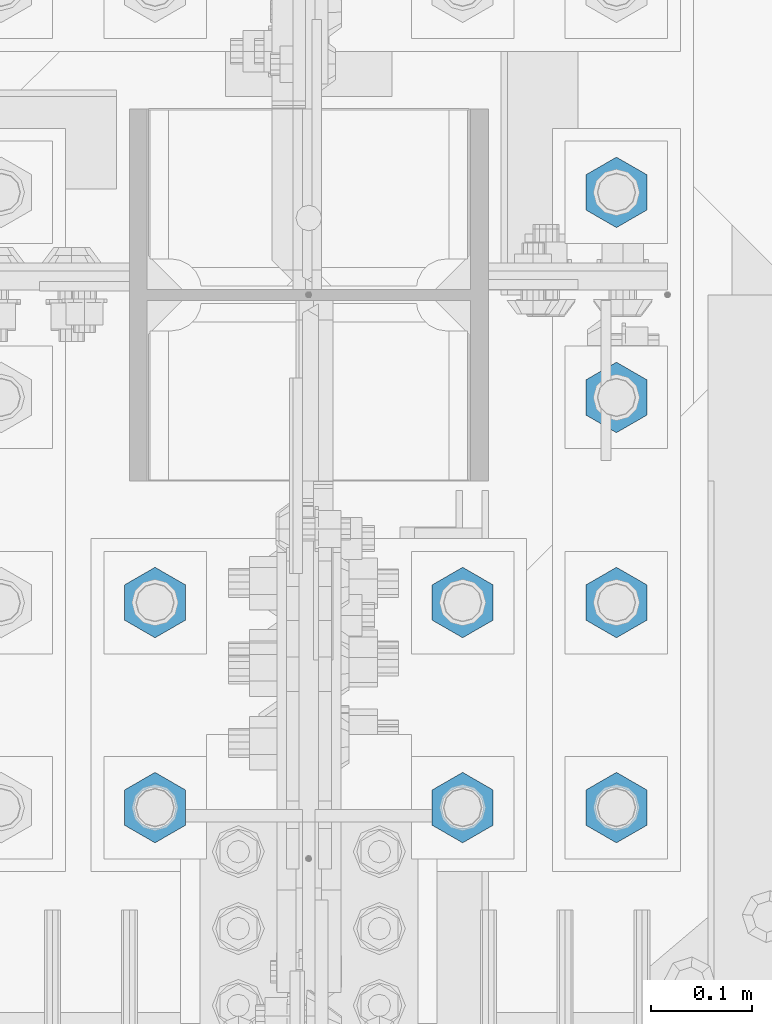
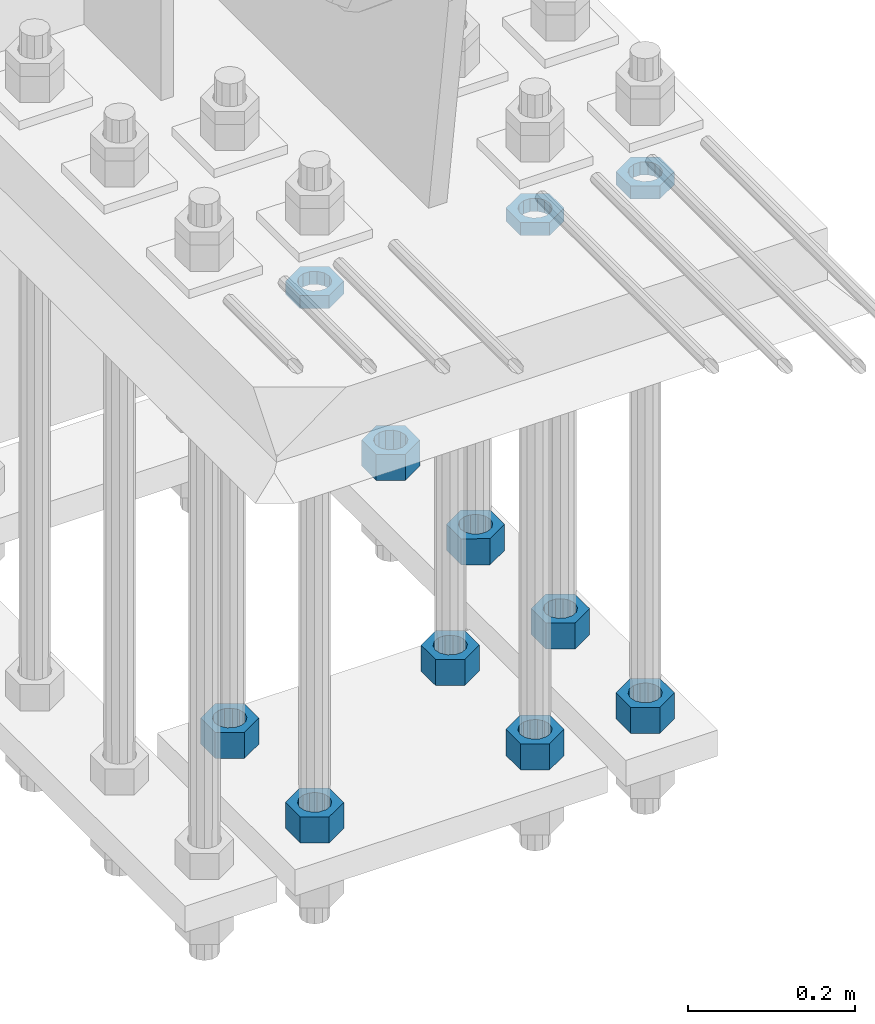
# One storey, part 2838 of 3843: 11 beams, 1 element without a shape of its own.
"""IFC2X3 building model written with IfcOpenShell, lengths in millimetres."""

from ifc_helpers import new_model, si_unit, frame, origin_with_axes, place, context, subcontext, project, spatial, faceted_brep, material, type_object, element, aggregate, save


model = new_model("IFC2X3")

# Units and contexts
model_context = context("Model", 3, precision=1e-05, world=origin_with_axes())
body_context = subcontext(model_context, "Body", "Model", "MODEL_VIEW")
ifc_project = project(units=[si_unit("LENGTHUNIT", "METRE", prefix="MILLI"), si_unit("AREAUNIT", "SQUARE_METRE"), si_unit("VOLUMEUNIT", "CUBIC_METRE"), si_unit("MASSUNIT", "GRAM", prefix="KILO"), si_unit("TIMEUNIT", "SECOND"), si_unit("PLANEANGLEUNIT", "RADIAN"), si_unit("SOLIDANGLEUNIT", "STERADIAN"), si_unit("THERMODYNAMICTEMPERATUREUNIT", "DEGREE_CELSIUS"), si_unit("LUMINOUSINTENSITYUNIT", "LUMEN")], contexts=[model_context])

# Site, building, storey
site_placement = place(None, origin_with_axes())
site = spatial("IfcSite", under=ifc_project, at=site_placement, CompositionType="ELEMENT")
building_placement = place(site_placement, origin_with_axes())
building = spatial("IfcBuilding", under=site, at=building_placement, Name="Undefined", CompositionType="ELEMENT")
storey_placement = place(building_placement, origin_with_axes())
storey = spatial("IfcBuildingStorey", under=building, at=storey_placement, Name="Undefined", CompositionType="ELEMENT", Elevation=0.0)

# Assembly, beams
assembly_placement = place(storey_placement, origin_with_axes())
assembly = element("IfcElementAssembly", 1, at=assembly_placement, inside=storey, Name="TEMPLATE", AssemblyPlace="NOTDEFINED", PredefinedType="RIGID_FRAME")
ifc_material = material(Name="STEEL/A572-50")
beam_type_1 = type_object("IfcBeamType", Name="1-1/2_HEAVY_HEX_NUT", PredefinedType="NOTDEFINED")
beam_1_placement = place(assembly_placement, frame((76860.4, 25107.9, 29298.9000015259), z_axis=(-1.0, 0.0, 0.0), x_axis=(0.0, 0.0, -1.0)))
beam_1 = element("IfcBeam", 2, at=beam_1_placement, type_object=beam_type_1, material=ifc_material, Name="NUT", ObjectType="1-1/2_HEAVY_HEX_NUT", context=body_context, shape_type="Brep", body=[
    faceted_brep([(0.0, -34.9199981689453, 0.0), (0.0, -17.4599990844727, -30.25), (38.0999999999985, -17.4599990844727, -30.25), (38.0999999999985, -34.9199981689453, 0.0), (0.0, 17.4599990844727, -30.25), (38.0999999999985, 17.4599990844727, -30.25), (0.0, 34.9199981689453, 0.0), (38.0999999999985, 34.9199981689453, 0.0), (0.0, 17.4599990844727, 30.25), (38.0999999999985, 17.4599990844727, 30.25), (0.0, -17.4599990844727, 30.25), (38.0999999999985, -17.4599990844727, 30.25), (0.0, 0.0, 20.6399993896484), (0.0, 8.9553601105581, 18.5959968835959), (38.0999999999985, 8.9553601105581, 18.5959968835959), (38.0999999999985, 0.0, 20.6399993896484), (0.0, 16.1370013209525, 12.8688291298167), (38.0999999999985, 16.1370013209525, 12.8688291298167), (0.0, 20.1225115123816, 4.59283194104501), (38.0999999999985, 20.1225115123816, 4.59283194104501), (0.0, 20.1225115123816, -4.59283194104501), (38.0999999999985, 20.1225115123816, -4.59283194104501), (0.0, 16.1370013209525, -12.8688291298167), (38.0999999999985, 16.1370013209525, -12.8688291298167), (0.0, 8.9553601105581, -18.5959968835959), (38.0999999999985, 8.9553601105581, -18.5959968835959), (0.0, 0.0, -20.6399993896484), (38.0999999999985, 0.0, -20.6399993896484), (0.0, -8.9553601105581, -18.5959968835959), (38.0999999999985, -8.9553601105581, -18.5959968835959), (0.0, -16.1370013209525, -12.8688291298167), (38.0999999999985, -16.1370013209525, -12.8688291298167), (0.0, -20.1225115123816, -4.59283194104501), (38.0999999999985, -20.1225115123816, -4.59283194104501), (0.0, -20.1225115123816, 4.59283194104501), (38.0999999999985, -20.1225115123816, 4.59283194104501), (0.0, -16.1370013209525, 12.8688291298167), (38.0999999999985, -16.1370013209525, 12.8688291298167), (0.0, -8.9553601105581, 18.5959968835959), (38.0999999999985, -8.9553601105581, 18.5959968835959)], [[[0, 1, 2, 3]], [[1, 4, 5, 2]], [[4, 6, 7, 5]], [[6, 8, 9, 7]], [[8, 10, 11, 9]], [[10, 0, 3, 11]], [[12, 13, 14, 15]], [[13, 16, 17, 14]], [[16, 18, 19, 17]], [[18, 20, 21, 19]], [[20, 22, 23, 21]], [[22, 24, 25, 23]], [[24, 26, 27, 25]], [[26, 28, 29, 27]], [[28, 30, 31, 29]], [[30, 32, 33, 31]], [[32, 34, 35, 33]], [[34, 36, 37, 35]], [[36, 38, 39, 37]], [[38, 12, 15, 39]], [[5, 7, 9, 11, 3, 2], [17, 19, 21, 23, 25, 27, 29, 31, 33, 35, 37, 39, 15, 14]], [[10, 8, 6, 4, 1, 0], [38, 36, 34, 32, 30, 28, 26, 24, 22, 20, 18, 16, 13, 12]]]),
])
beam_2_placement = place(assembly_placement, frame((76860.4, 25311.1, 29298.9000015259), z_axis=(-1.0, 0.0, 0.0), x_axis=(0.0, 0.0, -1.0)))
beam_2 = element("IfcBeam", 3, at=beam_2_placement, type_object=beam_type_1, material=ifc_material, Name="NUT", ObjectType="1-1/2_HEAVY_HEX_NUT", context=body_context, shape_type="Brep", body=[
    faceted_brep([(0.0, -34.9199981689453, 0.0), (0.0, -17.4599990844727, -30.25), (38.0999999999985, -17.4599990844727, -30.25), (38.0999999999985, -34.9199981689453, 0.0), (0.0, 17.4599990844727, -30.25), (38.0999999999985, 17.4599990844727, -30.25), (0.0, 34.9199981689453, 0.0), (38.0999999999985, 34.9199981689453, 0.0), (0.0, 17.4599990844727, 30.25), (38.0999999999985, 17.4599990844727, 30.25), (0.0, -17.4599990844727, 30.25), (38.0999999999985, -17.4599990844727, 30.25), (0.0, 0.0, 20.6399993896484), (0.0, 8.9553601105581, 18.5959968835959), (38.0999999999985, 8.9553601105581, 18.5959968835959), (38.0999999999985, 0.0, 20.6399993896484), (0.0, 16.1370013209525, 12.8688291298167), (38.0999999999985, 16.1370013209525, 12.8688291298167), (0.0, 20.1225115123816, 4.59283194104501), (38.0999999999985, 20.1225115123816, 4.59283194104501), (0.0, 20.1225115123816, -4.59283194104501), (38.0999999999985, 20.1225115123816, -4.59283194104501), (0.0, 16.1370013209525, -12.8688291298167), (38.0999999999985, 16.1370013209525, -12.8688291298167), (0.0, 8.9553601105581, -18.5959968835959), (38.0999999999985, 8.9553601105581, -18.5959968835959), (0.0, 0.0, -20.6399993896484), (38.0999999999985, 0.0, -20.6399993896484), (0.0, -8.9553601105581, -18.5959968835959), (38.0999999999985, -8.9553601105581, -18.5959968835959), (0.0, -16.1370013209525, -12.8688291298167), (38.0999999999985, -16.1370013209525, -12.8688291298167), (0.0, -20.1225115123816, -4.59283194104501), (38.0999999999985, -20.1225115123816, -4.59283194104501), (0.0, -20.1225115123816, 4.59283194104501), (38.0999999999985, -20.1225115123816, 4.59283194104501), (0.0, -16.1370013209525, 12.8688291298167), (38.0999999999985, -16.1370013209525, 12.8688291298167), (0.0, -8.9553601105581, 18.5959968835959), (38.0999999999985, -8.9553601105581, 18.5959968835959)], [[[0, 1, 2, 3]], [[1, 4, 5, 2]], [[4, 6, 7, 5]], [[6, 8, 9, 7]], [[8, 10, 11, 9]], [[10, 0, 3, 11]], [[12, 13, 14, 15]], [[13, 16, 17, 14]], [[16, 18, 19, 17]], [[18, 20, 21, 19]], [[20, 22, 23, 21]], [[22, 24, 25, 23]], [[24, 26, 27, 25]], [[26, 28, 29, 27]], [[28, 30, 31, 29]], [[30, 32, 33, 31]], [[32, 34, 35, 33]], [[34, 36, 37, 35]], [[36, 38, 39, 37]], [[38, 12, 15, 39]], [[5, 7, 9, 11, 3, 2], [17, 19, 21, 23, 25, 27, 29, 31, 33, 35, 37, 39, 15, 14]], [[10, 8, 6, 4, 1, 0], [38, 36, 34, 32, 30, 28, 26, 24, 22, 20, 18, 16, 13, 12]]]),
])
beam_3_placement = place(assembly_placement, frame((77165.2, 25107.9, 29298.9000015259), z_axis=(-1.0, 0.0, 0.0), x_axis=(0.0, 0.0, -1.0)))
beam_3 = element("IfcBeam", 4, at=beam_3_placement, type_object=beam_type_1, material=ifc_material, Name="NUT", ObjectType="1-1/2_HEAVY_HEX_NUT", context=body_context, shape_type="Brep", body=[
    faceted_brep([(0.0, -34.9199981689453, 0.0), (0.0, -17.4599990844727, -30.25), (38.0999999999985, -17.4599990844727, -30.25), (38.0999999999985, -34.9199981689453, 0.0), (0.0, 17.4599990844727, -30.25), (38.0999999999985, 17.4599990844727, -30.25), (0.0, 34.9199981689453, 0.0), (38.0999999999985, 34.9199981689453, 0.0), (0.0, 17.4599990844727, 30.25), (38.0999999999985, 17.4599990844727, 30.25), (0.0, -17.4599990844727, 30.25), (38.0999999999985, -17.4599990844727, 30.25), (0.0, 0.0, 20.6399993896484), (0.0, 8.9553601105581, 18.5959968835959), (38.0999999999985, 8.9553601105581, 18.5959968835959), (38.0999999999985, 0.0, 20.6399993896484), (0.0, 16.1370013209525, 12.8688291298167), (38.0999999999985, 16.1370013209525, 12.8688291298167), (0.0, 20.1225115123816, 4.59283194104501), (38.0999999999985, 20.1225115123816, 4.59283194104501), (0.0, 20.1225115123816, -4.59283194104501), (38.0999999999985, 20.1225115123816, -4.59283194104501), (0.0, 16.1370013209525, -12.8688291298167), (38.0999999999985, 16.1370013209525, -12.8688291298167), (0.0, 8.9553601105581, -18.5959968835959), (38.0999999999985, 8.9553601105581, -18.5959968835959), (0.0, 0.0, -20.6399993896484), (38.0999999999985, 0.0, -20.6399993896484), (0.0, -8.9553601105581, -18.5959968835959), (38.0999999999985, -8.9553601105581, -18.5959968835959), (0.0, -16.1370013209525, -12.8688291298167), (38.0999999999985, -16.1370013209525, -12.8688291298167), (0.0, -20.1225115123816, -4.59283194104501), (38.0999999999985, -20.1225115123816, -4.59283194104501), (0.0, -20.1225115123816, 4.59283194104501), (38.0999999999985, -20.1225115123816, 4.59283194104501), (0.0, -16.1370013209525, 12.8688291298167), (38.0999999999985, -16.1370013209525, 12.8688291298167), (0.0, -8.9553601105581, 18.5959968835959), (38.0999999999985, -8.9553601105581, 18.5959968835959)], [[[0, 1, 2, 3]], [[1, 4, 5, 2]], [[4, 6, 7, 5]], [[6, 8, 9, 7]], [[8, 10, 11, 9]], [[10, 0, 3, 11]], [[12, 13, 14, 15]], [[13, 16, 17, 14]], [[16, 18, 19, 17]], [[18, 20, 21, 19]], [[20, 22, 23, 21]], [[22, 24, 25, 23]], [[24, 26, 27, 25]], [[26, 28, 29, 27]], [[28, 30, 31, 29]], [[30, 32, 33, 31]], [[32, 34, 35, 33]], [[34, 36, 37, 35]], [[36, 38, 39, 37]], [[38, 12, 15, 39]], [[5, 7, 9, 11, 3, 2], [17, 19, 21, 23, 25, 27, 29, 31, 33, 35, 37, 39, 15, 14]], [[10, 8, 6, 4, 1, 0], [38, 36, 34, 32, 30, 28, 26, 24, 22, 20, 18, 16, 13, 12]]]),
])
beam_4_placement = place(assembly_placement, frame((77165.2, 25311.1, 29298.9000015259), z_axis=(-1.0, 0.0, 0.0), x_axis=(0.0, 0.0, -1.0)))
beam_4 = element("IfcBeam", 5, at=beam_4_placement, type_object=beam_type_1, material=ifc_material, Name="NUT", ObjectType="1-1/2_HEAVY_HEX_NUT", context=body_context, shape_type="Brep", body=[
    faceted_brep([(0.0, -34.9199981689453, 0.0), (0.0, -17.4599990844727, -30.25), (38.0999999999985, -17.4599990844727, -30.25), (38.0999999999985, -34.9199981689453, 0.0), (0.0, 17.4599990844727, -30.25), (38.0999999999985, 17.4599990844727, -30.25), (0.0, 34.9199981689453, 0.0), (38.0999999999985, 34.9199981689453, 0.0), (0.0, 17.4599990844727, 30.25), (38.0999999999985, 17.4599990844727, 30.25), (0.0, -17.4599990844727, 30.25), (38.0999999999985, -17.4599990844727, 30.25), (0.0, 0.0, 20.6399993896484), (0.0, 8.9553601105581, 18.5959968835959), (38.0999999999985, 8.9553601105581, 18.5959968835959), (38.0999999999985, 0.0, 20.6399993896484), (0.0, 16.1370013209525, 12.8688291298167), (38.0999999999985, 16.1370013209525, 12.8688291298167), (0.0, 20.1225115123816, 4.59283194104501), (38.0999999999985, 20.1225115123816, 4.59283194104501), (0.0, 20.1225115123816, -4.59283194104501), (38.0999999999985, 20.1225115123816, -4.59283194104501), (0.0, 16.1370013209525, -12.8688291298167), (38.0999999999985, 16.1370013209525, -12.8688291298167), (0.0, 8.9553601105581, -18.5959968835959), (38.0999999999985, 8.9553601105581, -18.5959968835959), (0.0, 0.0, -20.6399993896484), (38.0999999999985, 0.0, -20.6399993896484), (0.0, -8.9553601105581, -18.5959968835959), (38.0999999999985, -8.9553601105581, -18.5959968835959), (0.0, -16.1370013209525, -12.8688291298167), (38.0999999999985, -16.1370013209525, -12.8688291298167), (0.0, -20.1225115123816, -4.59283194104501), (38.0999999999985, -20.1225115123816, -4.59283194104501), (0.0, -20.1225115123816, 4.59283194104501), (38.0999999999985, -20.1225115123816, 4.59283194104501), (0.0, -16.1370013209525, 12.8688291298167), (38.0999999999985, -16.1370013209525, 12.8688291298167), (0.0, -8.9553601105581, 18.5959968835959), (38.0999999999985, -8.9553601105581, 18.5959968835959)], [[[0, 1, 2, 3]], [[1, 4, 5, 2]], [[4, 6, 7, 5]], [[6, 8, 9, 7]], [[8, 10, 11, 9]], [[10, 0, 3, 11]], [[12, 13, 14, 15]], [[13, 16, 17, 14]], [[16, 18, 19, 17]], [[18, 20, 21, 19]], [[20, 22, 23, 21]], [[22, 24, 25, 23]], [[24, 26, 27, 25]], [[26, 28, 29, 27]], [[28, 30, 31, 29]], [[30, 32, 33, 31]], [[32, 34, 35, 33]], [[34, 36, 37, 35]], [[36, 38, 39, 37]], [[38, 12, 15, 39]], [[5, 7, 9, 11, 3, 2], [17, 19, 21, 23, 25, 27, 29, 31, 33, 35, 37, 39, 15, 14]], [[10, 8, 6, 4, 1, 0], [38, 36, 34, 32, 30, 28, 26, 24, 22, 20, 18, 16, 13, 12]]]),
])
beam_5_placement = place(assembly_placement, frame((77317.6, 25717.5, 29298.9000015259), z_axis=(1.0, 0.0, 0.0), x_axis=(0.0, 0.0, -1.0)))
beam_5 = element("IfcBeam", 6, at=beam_5_placement, type_object=beam_type_1, material=ifc_material, Name="NUT", ObjectType="1-1/2_HEAVY_HEX_NUT", context=body_context, shape_type="Brep", body=[
    faceted_brep([(0.0, -34.9199981689453, 0.0), (0.0, -17.4599990844727, -30.25), (38.0999999999985, -17.4599990844727, -30.25), (38.0999999999985, -34.9199981689453, 0.0), (0.0, 17.4599990844727, -30.25), (38.0999999999985, 17.4599990844727, -30.25), (0.0, 34.9199981689453, 0.0), (38.0999999999985, 34.9199981689453, 0.0), (0.0, 17.4599990844727, 30.25), (38.0999999999985, 17.4599990844727, 30.25), (0.0, -17.4599990844727, 30.25), (38.0999999999985, -17.4599990844727, 30.25), (0.0, 0.0, 20.6399993896484), (0.0, 8.9553601105581, 18.5959968835959), (38.0999999999985, 8.9553601105581, 18.5959968835959), (38.0999999999985, 0.0, 20.6399993896484), (0.0, 16.1370013209525, 12.8688291298167), (38.0999999999985, 16.1370013209525, 12.8688291298167), (0.0, 20.1225115123816, 4.59283194104501), (38.0999999999985, 20.1225115123816, 4.59283194104501), (0.0, 20.1225115123816, -4.59283194104501), (38.0999999999985, 20.1225115123816, -4.59283194104501), (0.0, 16.1370013209525, -12.8688291298167), (38.0999999999985, 16.1370013209525, -12.8688291298167), (0.0, 8.9553601105581, -18.5959968835959), (38.0999999999985, 8.9553601105581, -18.5959968835959), (0.0, 0.0, -20.6399993896484), (38.0999999999985, 0.0, -20.6399993896484), (0.0, -8.9553601105581, -18.5959968835959), (38.0999999999985, -8.9553601105581, -18.5959968835959), (0.0, -16.1370013209525, -12.8688291298167), (38.0999999999985, -16.1370013209525, -12.8688291298167), (0.0, -20.1225115123816, -4.59283194104501), (38.0999999999985, -20.1225115123816, -4.59283194104501), (0.0, -20.1225115123816, 4.59283194104501), (38.0999999999985, -20.1225115123816, 4.59283194104501), (0.0, -16.1370013209525, 12.8688291298167), (38.0999999999985, -16.1370013209525, 12.8688291298167), (0.0, -8.9553601105581, 18.5959968835959), (38.0999999999985, -8.9553601105581, 18.5959968835959)], [[[0, 1, 2, 3]], [[1, 4, 5, 2]], [[4, 6, 7, 5]], [[6, 8, 9, 7]], [[8, 10, 11, 9]], [[10, 0, 3, 11]], [[12, 13, 14, 15]], [[13, 16, 17, 14]], [[16, 18, 19, 17]], [[18, 20, 21, 19]], [[20, 22, 23, 21]], [[22, 24, 25, 23]], [[24, 26, 27, 25]], [[26, 28, 29, 27]], [[28, 30, 31, 29]], [[30, 32, 33, 31]], [[32, 34, 35, 33]], [[34, 36, 37, 35]], [[36, 38, 39, 37]], [[38, 12, 15, 39]], [[5, 7, 9, 11, 3, 2], [17, 19, 21, 23, 25, 27, 29, 31, 33, 35, 37, 39, 15, 14]], [[10, 8, 6, 4, 1, 0], [38, 36, 34, 32, 30, 28, 26, 24, 22, 20, 18, 16, 13, 12]]]),
])
beam_6_placement = place(assembly_placement, frame((77317.6, 25514.3, 29298.9000015259), z_axis=(1.0, 0.0, 0.0), x_axis=(0.0, 0.0, -1.0)))
beam_6 = element("IfcBeam", 7, at=beam_6_placement, type_object=beam_type_1, material=ifc_material, Name="NUT", ObjectType="1-1/2_HEAVY_HEX_NUT", context=body_context, shape_type="Brep", body=[
    faceted_brep([(0.0, -34.9199981689453, 0.0), (0.0, -17.4599990844727, -30.25), (38.0999999999985, -17.4599990844727, -30.25), (38.0999999999985, -34.9199981689453, 0.0), (0.0, 17.4599990844727, -30.25), (38.0999999999985, 17.4599990844727, -30.25), (0.0, 34.9199981689453, 0.0), (38.0999999999985, 34.9199981689453, 0.0), (0.0, 17.4599990844727, 30.25), (38.0999999999985, 17.4599990844727, 30.25), (0.0, -17.4599990844727, 30.25), (38.0999999999985, -17.4599990844727, 30.25), (0.0, 0.0, 20.6399993896484), (0.0, 8.9553601105581, 18.5959968835959), (38.0999999999985, 8.9553601105581, 18.5959968835959), (38.0999999999985, 0.0, 20.6399993896484), (0.0, 16.1370013209525, 12.8688291298167), (38.0999999999985, 16.1370013209525, 12.8688291298167), (0.0, 20.1225115123816, 4.59283194104501), (38.0999999999985, 20.1225115123816, 4.59283194104501), (0.0, 20.1225115123816, -4.59283194104501), (38.0999999999985, 20.1225115123816, -4.59283194104501), (0.0, 16.1370013209525, -12.8688291298167), (38.0999999999985, 16.1370013209525, -12.8688291298167), (0.0, 8.9553601105581, -18.5959968835959), (38.0999999999985, 8.9553601105581, -18.5959968835959), (0.0, 0.0, -20.6399993896484), (38.0999999999985, 0.0, -20.6399993896484), (0.0, -8.9553601105581, -18.5959968835959), (38.0999999999985, -8.9553601105581, -18.5959968835959), (0.0, -16.1370013209525, -12.8688291298167), (38.0999999999985, -16.1370013209525, -12.8688291298167), (0.0, -20.1225115123816, -4.59283194104501), (38.0999999999985, -20.1225115123816, -4.59283194104501), (0.0, -20.1225115123816, 4.59283194104501), (38.0999999999985, -20.1225115123816, 4.59283194104501), (0.0, -16.1370013209525, 12.8688291298167), (38.0999999999985, -16.1370013209525, 12.8688291298167), (0.0, -8.9553601105581, 18.5959968835959), (38.0999999999985, -8.9553601105581, 18.5959968835959)], [[[0, 1, 2, 3]], [[1, 4, 5, 2]], [[4, 6, 7, 5]], [[6, 8, 9, 7]], [[8, 10, 11, 9]], [[10, 0, 3, 11]], [[12, 13, 14, 15]], [[13, 16, 17, 14]], [[16, 18, 19, 17]], [[18, 20, 21, 19]], [[20, 22, 23, 21]], [[22, 24, 25, 23]], [[24, 26, 27, 25]], [[26, 28, 29, 27]], [[28, 30, 31, 29]], [[30, 32, 33, 31]], [[32, 34, 35, 33]], [[34, 36, 37, 35]], [[36, 38, 39, 37]], [[38, 12, 15, 39]], [[5, 7, 9, 11, 3, 2], [17, 19, 21, 23, 25, 27, 29, 31, 33, 35, 37, 39, 15, 14]], [[10, 8, 6, 4, 1, 0], [38, 36, 34, 32, 30, 28, 26, 24, 22, 20, 18, 16, 13, 12]]]),
])
beam_7_placement = place(assembly_placement, frame((77317.6, 25311.1, 29298.9000015259), z_axis=(-1.0, 0.0, 0.0), x_axis=(0.0, 0.0, -1.0)))
beam_7 = element("IfcBeam", 8, at=beam_7_placement, type_object=beam_type_1, material=ifc_material, Name="NUT", ObjectType="1-1/2_HEAVY_HEX_NUT", context=body_context, shape_type="Brep", body=[
    faceted_brep([(0.0, -34.9199981689453, 0.0), (0.0, -17.4599990844727, -30.25), (38.0999999999985, -17.4599990844727, -30.25), (38.0999999999985, -34.9199981689453, 0.0), (0.0, 17.4599990844727, -30.25), (38.0999999999985, 17.4599990844727, -30.25), (0.0, 34.9199981689453, 0.0), (38.0999999999985, 34.9199981689453, 0.0), (0.0, 17.4599990844727, 30.25), (38.0999999999985, 17.4599990844727, 30.25), (0.0, -17.4599990844727, 30.25), (38.0999999999985, -17.4599990844727, 30.25), (0.0, 0.0, 20.6399993896484), (0.0, 8.9553601105581, 18.5959968835959), (38.0999999999985, 8.9553601105581, 18.5959968835959), (38.0999999999985, 0.0, 20.6399993896484), (0.0, 16.1370013209525, 12.8688291298167), (38.0999999999985, 16.1370013209525, 12.8688291298167), (0.0, 20.1225115123816, 4.59283194104501), (38.0999999999985, 20.1225115123816, 4.59283194104501), (0.0, 20.1225115123816, -4.59283194104501), (38.0999999999985, 20.1225115123816, -4.59283194104501), (0.0, 16.1370013209525, -12.8688291298167), (38.0999999999985, 16.1370013209525, -12.8688291298167), (0.0, 8.9553601105581, -18.5959968835959), (38.0999999999985, 8.9553601105581, -18.5959968835959), (0.0, 0.0, -20.6399993896484), (38.0999999999985, 0.0, -20.6399993896484), (0.0, -8.9553601105581, -18.5959968835959), (38.0999999999985, -8.9553601105581, -18.5959968835959), (0.0, -16.1370013209525, -12.8688291298167), (38.0999999999985, -16.1370013209525, -12.8688291298167), (0.0, -20.1225115123816, -4.59283194104501), (38.0999999999985, -20.1225115123816, -4.59283194104501), (0.0, -20.1225115123816, 4.59283194104501), (38.0999999999985, -20.1225115123816, 4.59283194104501), (0.0, -16.1370013209525, 12.8688291298167), (38.0999999999985, -16.1370013209525, 12.8688291298167), (0.0, -8.9553601105581, 18.5959968835959), (38.0999999999985, -8.9553601105581, 18.5959968835959)], [[[0, 1, 2, 3]], [[1, 4, 5, 2]], [[4, 6, 7, 5]], [[6, 8, 9, 7]], [[8, 10, 11, 9]], [[10, 0, 3, 11]], [[12, 13, 14, 15]], [[13, 16, 17, 14]], [[16, 18, 19, 17]], [[18, 20, 21, 19]], [[20, 22, 23, 21]], [[22, 24, 25, 23]], [[24, 26, 27, 25]], [[26, 28, 29, 27]], [[28, 30, 31, 29]], [[30, 32, 33, 31]], [[32, 34, 35, 33]], [[34, 36, 37, 35]], [[36, 38, 39, 37]], [[38, 12, 15, 39]], [[5, 7, 9, 11, 3, 2], [17, 19, 21, 23, 25, 27, 29, 31, 33, 35, 37, 39, 15, 14]], [[10, 8, 6, 4, 1, 0], [38, 36, 34, 32, 30, 28, 26, 24, 22, 20, 18, 16, 13, 12]]]),
])
beam_8_placement = place(assembly_placement, frame((77317.6, 25107.9, 29298.9000015259), z_axis=(-1.0, 0.0, 0.0), x_axis=(0.0, 0.0, -1.0)))
beam_8 = element("IfcBeam", 9, at=beam_8_placement, type_object=beam_type_1, material=ifc_material, Name="NUT", ObjectType="1-1/2_HEAVY_HEX_NUT", context=body_context, shape_type="Brep", body=[
    faceted_brep([(0.0, -34.9199981689453, 0.0), (0.0, -17.4599990844727, -30.25), (38.0999999999985, -17.4599990844727, -30.25), (38.0999999999985, -34.9199981689453, 0.0), (0.0, 17.4599990844727, -30.25), (38.0999999999985, 17.4599990844727, -30.25), (0.0, 34.9199981689453, 0.0), (38.0999999999985, 34.9199981689453, 0.0), (0.0, 17.4599990844727, 30.25), (38.0999999999985, 17.4599990844727, 30.25), (0.0, -17.4599990844727, 30.25), (38.0999999999985, -17.4599990844727, 30.25), (0.0, 0.0, 20.6399993896484), (0.0, 8.9553601105581, 18.5959968835959), (38.0999999999985, 8.9553601105581, 18.5959968835959), (38.0999999999985, 0.0, 20.6399993896484), (0.0, 16.1370013209525, 12.8688291298167), (38.0999999999985, 16.1370013209525, 12.8688291298167), (0.0, 20.1225115123816, 4.59283194104501), (38.0999999999985, 20.1225115123816, 4.59283194104501), (0.0, 20.1225115123816, -4.59283194104501), (38.0999999999985, 20.1225115123816, -4.59283194104501), (0.0, 16.1370013209525, -12.8688291298167), (38.0999999999985, 16.1370013209525, -12.8688291298167), (0.0, 8.9553601105581, -18.5959968835959), (38.0999999999985, 8.9553601105581, -18.5959968835959), (0.0, 0.0, -20.6399993896484), (38.0999999999985, 0.0, -20.6399993896484), (0.0, -8.9553601105581, -18.5959968835959), (38.0999999999985, -8.9553601105581, -18.5959968835959), (0.0, -16.1370013209525, -12.8688291298167), (38.0999999999985, -16.1370013209525, -12.8688291298167), (0.0, -20.1225115123816, -4.59283194104501), (38.0999999999985, -20.1225115123816, -4.59283194104501), (0.0, -20.1225115123816, 4.59283194104501), (38.0999999999985, -20.1225115123816, 4.59283194104501), (0.0, -16.1370013209525, 12.8688291298167), (38.0999999999985, -16.1370013209525, 12.8688291298167), (0.0, -8.9553601105581, 18.5959968835959), (38.0999999999985, -8.9553601105581, 18.5959968835959)], [[[0, 1, 2, 3]], [[1, 4, 5, 2]], [[4, 6, 7, 5]], [[6, 8, 9, 7]], [[8, 10, 11, 9]], [[10, 0, 3, 11]], [[12, 13, 14, 15]], [[13, 16, 17, 14]], [[16, 18, 19, 17]], [[18, 20, 21, 19]], [[20, 22, 23, 21]], [[22, 24, 25, 23]], [[24, 26, 27, 25]], [[26, 28, 29, 27]], [[28, 30, 31, 29]], [[30, 32, 33, 31]], [[32, 34, 35, 33]], [[34, 36, 37, 35]], [[36, 38, 39, 37]], [[38, 12, 15, 39]], [[5, 7, 9, 11, 3, 2], [17, 19, 21, 23, 25, 27, 29, 31, 33, 35, 37, 39, 15, 14]], [[10, 8, 6, 4, 1, 0], [38, 36, 34, 32, 30, 28, 26, 24, 22, 20, 18, 16, 13, 12]]]),
])
beam_type_2 = type_object("IfcBeamType", Name="1-1/2_HALF_NUT", PredefinedType="NOTDEFINED")
beam_9_placement = place(assembly_placement, frame((77165.2, 25107.9, 30060.9), z_axis=(-1.0, 0.0, 0.0), x_axis=(0.0, 0.0, -1.0)))
beam_9 = element("IfcBeam", 10, at=beam_9_placement, type_object=beam_type_2, material=ifc_material, Name="NUT", ObjectType="1-1/2_HALF_NUT", context=body_context, shape_type="Brep", body=[
    faceted_brep([(0.0, -34.9199981689453, 0.0), (0.0, -17.4599990844727, -30.25), (19.0500000000029, -17.4599990844727, -30.25), (19.0500000000029, -34.9199981689453, 0.0), (0.0, 17.4599990844727, -30.25), (19.0500000000029, 17.4599990844727, -30.25), (0.0, 34.9199981689453, 0.0), (19.0500000000029, 34.9199981689453, 0.0), (0.0, 17.4599990844727, 30.25), (19.0500000000029, 17.4599990844727, 30.25), (0.0, -17.4599990844727, 30.25), (19.0500000000029, -17.4599990844727, 30.25), (0.0, 0.0, 20.6399993896484), (0.0, 8.9553601105581, 18.5959968835959), (19.0500000000029, 8.95536011056538, 18.5959968835959), (19.0500000000029, 0.0, 20.6399993896484), (0.0, 16.1370013209525, 12.8688291298167), (19.0500000000029, 16.1370013209489, 12.8688291298167), (0.0, 20.1225115123816, 4.59283194104501), (19.0500000000029, 20.1225115123852, 4.59283194104501), (0.0, 20.1225115123816, -4.59283194104501), (19.0500000000029, 20.1225115123852, -4.59283194104501), (0.0, 16.1370013209525, -12.8688291298167), (19.0500000000029, 16.1370013209489, -12.8688291298167), (0.0, 8.9553601105581, -18.5959968835959), (19.0500000000029, 8.95536011056538, -18.5959968835959), (0.0, 0.0, -20.6399993896484), (19.0500000000029, 0.0, -20.6399993896484), (0.0, -8.9553601105581, -18.5959968835959), (19.0500000000029, -8.95536011056538, -18.5959968835959), (0.0, -16.1370013209525, -12.8688291298167), (19.0500000000029, -16.1370013209489, -12.8688291298167), (0.0, -20.1225115123816, -4.59283194104501), (19.0500000000029, -20.1225115123852, -4.59283194104501), (0.0, -20.1225115123816, 4.59283194104501), (19.0500000000029, -20.1225115123852, 4.59283194104501), (0.0, -16.1370013209525, 12.8688291298167), (19.0500000000029, -16.1370013209489, 12.8688291298167), (0.0, -8.9553601105581, 18.5959968835959), (19.0500000000029, -8.95536011056538, 18.5959968835959)], [[[0, 1, 2, 3]], [[1, 4, 5, 2]], [[4, 6, 7, 5]], [[6, 8, 9, 7]], [[8, 10, 11, 9]], [[10, 0, 3, 11]], [[12, 13, 14, 15]], [[13, 16, 17, 14]], [[16, 18, 19, 17]], [[18, 20, 21, 19]], [[20, 22, 23, 21]], [[22, 24, 25, 23]], [[24, 26, 27, 25]], [[26, 28, 29, 27]], [[28, 30, 31, 29]], [[30, 32, 33, 31]], [[32, 34, 35, 33]], [[34, 36, 37, 35]], [[36, 38, 39, 37]], [[38, 12, 15, 39]], [[5, 7, 9, 11, 3, 2], [17, 19, 21, 23, 25, 27, 29, 31, 33, 35, 37, 39, 15, 14]], [[10, 8, 6, 4, 1, 0], [38, 36, 34, 32, 30, 28, 26, 24, 22, 20, 18, 16, 13, 12]]]),
])
beam_10_placement = place(assembly_placement, frame((77317.6, 25107.9, 30060.9), z_axis=(-1.0, 0.0, 0.0), x_axis=(0.0, 0.0, -1.0)))
beam_10 = element("IfcBeam", 11, at=beam_10_placement, type_object=beam_type_2, material=ifc_material, Name="NUT", ObjectType="1-1/2_HALF_NUT", context=body_context, shape_type="Brep", body=[
    faceted_brep([(0.0, -34.9199981689453, 0.0), (0.0, -17.4599990844727, -30.25), (19.0500000000029, -17.4599990844727, -30.25), (19.0500000000029, -34.9199981689453, 0.0), (0.0, 17.4599990844727, -30.25), (19.0500000000029, 17.4599990844727, -30.25), (0.0, 34.9199981689453, 0.0), (19.0500000000029, 34.9199981689453, 0.0), (0.0, 17.4599990844727, 30.25), (19.0500000000029, 17.4599990844727, 30.25), (0.0, -17.4599990844727, 30.25), (19.0500000000029, -17.4599990844727, 30.25), (0.0, 0.0, 20.6399993896484), (0.0, 8.9553601105581, 18.5959968835959), (19.0500000000029, 8.95536011056538, 18.5959968835959), (19.0500000000029, 0.0, 20.6399993896484), (0.0, 16.1370013209525, 12.8688291298167), (19.0500000000029, 16.1370013209489, 12.8688291298167), (0.0, 20.1225115123816, 4.59283194104501), (19.0500000000029, 20.1225115123852, 4.59283194104501), (0.0, 20.1225115123816, -4.59283194104501), (19.0500000000029, 20.1225115123852, -4.59283194104501), (0.0, 16.1370013209525, -12.8688291298167), (19.0500000000029, 16.1370013209489, -12.8688291298167), (0.0, 8.9553601105581, -18.5959968835959), (19.0500000000029, 8.95536011056538, -18.5959968835959), (0.0, 0.0, -20.6399993896484), (19.0500000000029, 0.0, -20.6399993896484), (0.0, -8.9553601105581, -18.5959968835959), (19.0500000000029, -8.95536011056538, -18.5959968835959), (0.0, -16.1370013209525, -12.8688291298167), (19.0500000000029, -16.1370013209489, -12.8688291298167), (0.0, -20.1225115123816, -4.59283194104501), (19.0500000000029, -20.1225115123852, -4.59283194104501), (0.0, -20.1225115123816, 4.59283194104501), (19.0500000000029, -20.1225115123852, 4.59283194104501), (0.0, -16.1370013209525, 12.8688291298167), (19.0500000000029, -16.1370013209489, 12.8688291298167), (0.0, -8.9553601105581, 18.5959968835959), (19.0500000000029, -8.95536011056538, 18.5959968835959)], [[[0, 1, 2, 3]], [[1, 4, 5, 2]], [[4, 6, 7, 5]], [[6, 8, 9, 7]], [[8, 10, 11, 9]], [[10, 0, 3, 11]], [[12, 13, 14, 15]], [[13, 16, 17, 14]], [[16, 18, 19, 17]], [[18, 20, 21, 19]], [[20, 22, 23, 21]], [[22, 24, 25, 23]], [[24, 26, 27, 25]], [[26, 28, 29, 27]], [[28, 30, 31, 29]], [[30, 32, 33, 31]], [[32, 34, 35, 33]], [[34, 36, 37, 35]], [[36, 38, 39, 37]], [[38, 12, 15, 39]], [[5, 7, 9, 11, 3, 2], [17, 19, 21, 23, 25, 27, 29, 31, 33, 35, 37, 39, 15, 14]], [[10, 8, 6, 4, 1, 0], [38, 36, 34, 32, 30, 28, 26, 24, 22, 20, 18, 16, 13, 12]]]),
])
beam_11_placement = place(assembly_placement, frame((76860.4, 25107.9, 30060.9), z_axis=(-1.0, 0.0, 0.0), x_axis=(0.0, 0.0, -1.0)))
beam_11 = element("IfcBeam", 12, at=beam_11_placement, type_object=beam_type_2, material=ifc_material, Name="NUT", ObjectType="1-1/2_HALF_NUT", context=body_context, shape_type="Brep", body=[
    faceted_brep([(0.0, -34.9199981689453, 0.0), (0.0, -17.4599990844727, -30.25), (19.0500000000029, -17.4599990844727, -30.25), (19.0500000000029, -34.9199981689453, 0.0), (0.0, 17.4599990844727, -30.25), (19.0500000000029, 17.4599990844727, -30.25), (0.0, 34.9199981689453, 0.0), (19.0500000000029, 34.9199981689453, 0.0), (0.0, 17.4599990844727, 30.25), (19.0500000000029, 17.4599990844727, 30.25), (0.0, -17.4599990844727, 30.25), (19.0500000000029, -17.4599990844727, 30.25), (0.0, 0.0, 20.6399993896484), (0.0, 8.9553601105581, 18.5959968835959), (19.0500000000029, 8.95536011056538, 18.5959968835959), (19.0500000000029, 0.0, 20.6399993896484), (0.0, 16.1370013209525, 12.8688291298167), (19.0500000000029, 16.1370013209489, 12.8688291298167), (0.0, 20.1225115123816, 4.59283194104501), (19.0500000000029, 20.1225115123852, 4.59283194104501), (0.0, 20.1225115123816, -4.59283194104501), (19.0500000000029, 20.1225115123852, -4.59283194104501), (0.0, 16.1370013209525, -12.8688291298167), (19.0500000000029, 16.1370013209489, -12.8688291298167), (0.0, 8.9553601105581, -18.5959968835959), (19.0500000000029, 8.95536011056538, -18.5959968835959), (0.0, 0.0, -20.6399993896484), (19.0500000000029, 0.0, -20.6399993896484), (0.0, -8.9553601105581, -18.5959968835959), (19.0500000000029, -8.95536011056538, -18.5959968835959), (0.0, -16.1370013209525, -12.8688291298167), (19.0500000000029, -16.1370013209489, -12.8688291298167), (0.0, -20.1225115123816, -4.59283194104501), (19.0500000000029, -20.1225115123852, -4.59283194104501), (0.0, -20.1225115123816, 4.59283194104501), (19.0500000000029, -20.1225115123852, 4.59283194104501), (0.0, -16.1370013209525, 12.8688291298167), (19.0500000000029, -16.1370013209489, 12.8688291298167), (0.0, -8.9553601105581, 18.5959968835959), (19.0500000000029, -8.95536011056538, 18.5959968835959)], [[[0, 1, 2, 3]], [[1, 4, 5, 2]], [[4, 6, 7, 5]], [[6, 8, 9, 7]], [[8, 10, 11, 9]], [[10, 0, 3, 11]], [[12, 13, 14, 15]], [[13, 16, 17, 14]], [[16, 18, 19, 17]], [[18, 20, 21, 19]], [[20, 22, 23, 21]], [[22, 24, 25, 23]], [[24, 26, 27, 25]], [[26, 28, 29, 27]], [[28, 30, 31, 29]], [[30, 32, 33, 31]], [[32, 34, 35, 33]], [[34, 36, 37, 35]], [[36, 38, 39, 37]], [[38, 12, 15, 39]], [[5, 7, 9, 11, 3, 2], [17, 19, 21, 23, 25, 27, 29, 31, 33, 35, 37, 39, 15, 14]], [[10, 8, 6, 4, 1, 0], [38, 36, 34, 32, 30, 28, 26, 24, 22, 20, 18, 16, 13, 12]]]),
])
aggregate(assembly, [beam_1, beam_2, beam_3, beam_4, beam_5, beam_6, beam_7, beam_8, beam_9, beam_10, beam_11])

save(model, "model.ifc")
